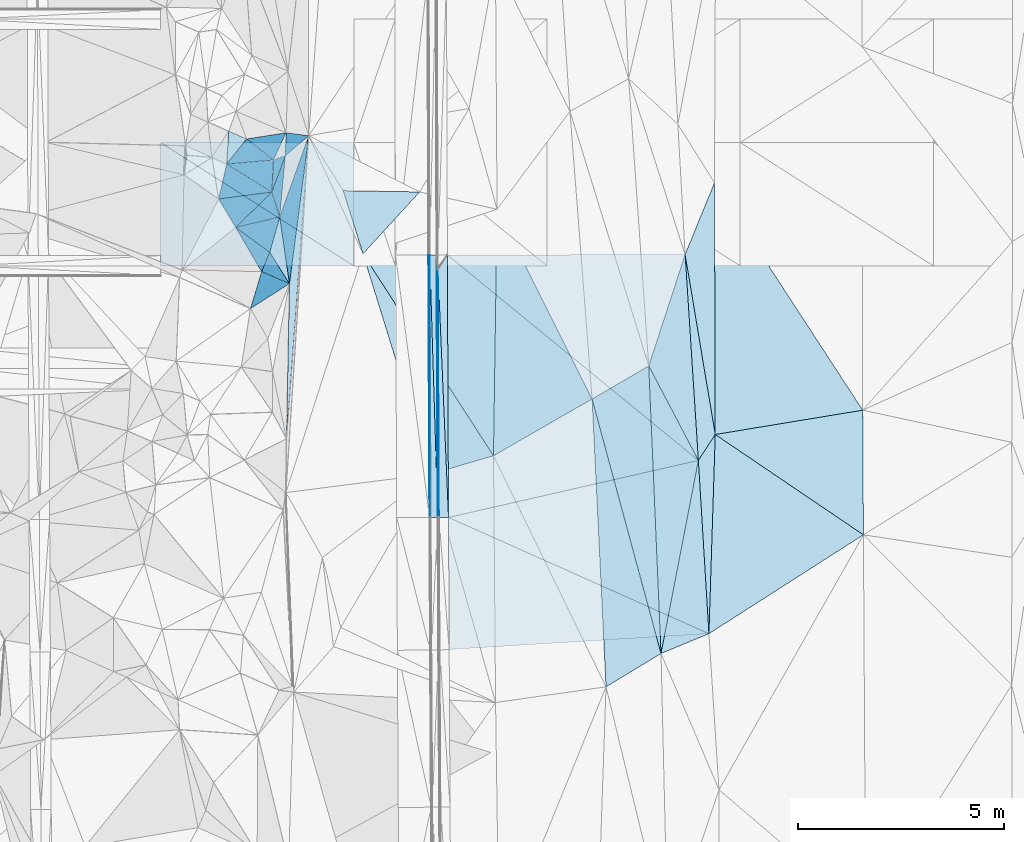
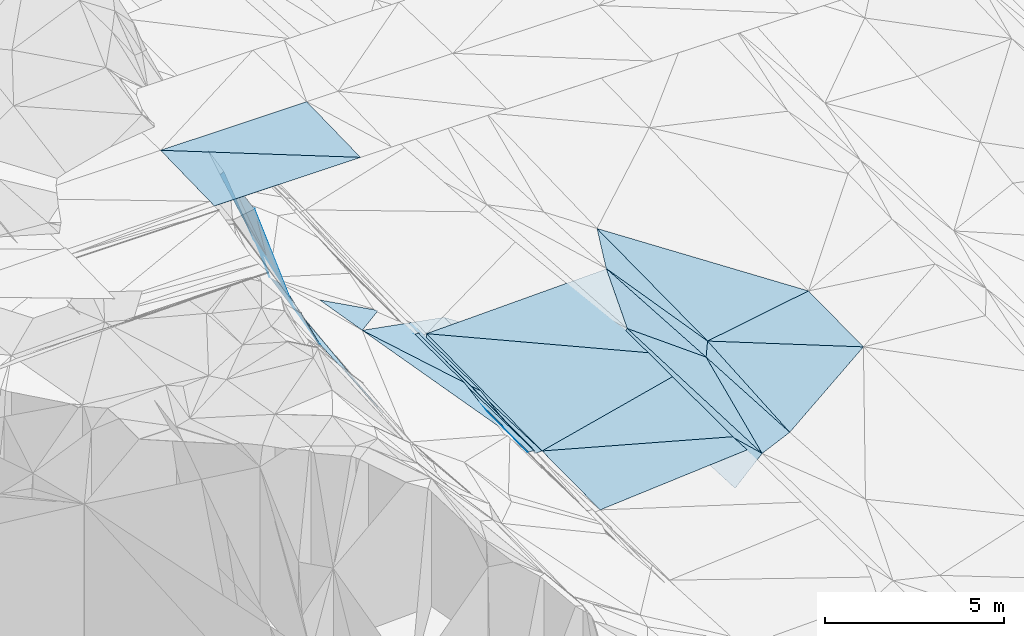
# One storey, part 64 of 275: 45 plates.
"""IFC2X3 building model written with IfcOpenShell, lengths in millimetres."""

from ifc_helpers import new_model, si_unit, frame, origin_with_axes, place, context, subcontext, project, spatial, polyline, outline, extrude, material, type_object, element, save


model = new_model("IFC2X3")

# Units and contexts
model_context = context("Model", 3, precision=1e-05, world=origin_with_axes())
body_context = subcontext(model_context, "Body", "Model", "MODEL_VIEW")
ifc_project = project(units=[si_unit("LENGTHUNIT", "METRE", prefix="MILLI"), si_unit("AREAUNIT", "SQUARE_METRE"), si_unit("VOLUMEUNIT", "CUBIC_METRE"), si_unit("MASSUNIT", "GRAM", prefix="KILO"), si_unit("TIMEUNIT", "SECOND"), si_unit("PLANEANGLEUNIT", "RADIAN"), si_unit("SOLIDANGLEUNIT", "STERADIAN"), si_unit("THERMODYNAMICTEMPERATUREUNIT", "DEGREE_CELSIUS"), si_unit("LUMINOUSINTENSITYUNIT", "LUMEN")], contexts=[model_context])

# Site, building, storey
site_placement = place(None, origin_with_axes())
site = spatial("IfcSite", under=ifc_project, at=site_placement, CompositionType="ELEMENT")
building_placement = place(site_placement, origin_with_axes())
building = spatial("IfcBuilding", under=site, at=building_placement, Name="Undefined", CompositionType="ELEMENT")
storey_placement = place(building_placement, origin_with_axes())
storey = spatial("IfcBuildingStorey", under=building, at=storey_placement, Name="Undefined", CompositionType="ELEMENT", Elevation=0.0)

# Plates
ifc_material = material()
plate_type_1 = type_object("IfcPlateType", PredefinedType="NOTDEFINED")
plate_1_placement = place(storey_placement, frame((-94083.1872128523, 60194.4197135059, 42150.4907383487), z_axis=(-0.970145132362982, 0.000666427097480044, -0.242524180294124), x_axis=(0.00428883012039787, -0.999792707106307, -0.0199034859569888)))
element("IfcPlate", 1, at=plate_1_placement, inside=storey, type_object=plate_type_1, material=ifc_material, Name="00_PR", context=body_context, shape_type="SweptSolid", body=[
    extrude(outline(polyline([(0.0, 0.0), (6024.77392578125, 2.10566213354468e-08), (6022.52880859375, 123.672775268555), (0.0, 0.0)])), frame((-8.85201319254618e-08, 2.18876761149539e-07, -0.5000001331573), z_axis=(0.0, 0.0, 1.0), x_axis=(1.0, 0.0, 0.0)), (0.0, 0.0, 1.0), 1.0),
])
plate_type_2 = type_object("IfcPlateType", PredefinedType="NOTDEFINED")
plate_2_placement = place(storey_placement, frame((-94314.0681795812, 60554.8896262147, 42276.9291978691), z_axis=(-0.020065563650007, 0.019660330856377, -0.99960534439649), x_axis=(0.999793129428669, 0.00372195810997011, -0.0199961340027595)))
element("IfcPlate", 2, at=plate_2_placement, inside=storey, type_object=plate_type_2, material=ifc_material, Name="00_PR", context=body_context, shape_type="SweptSolid", body=[
    extrude(outline(polyline([(0.0, 0.0), (30.0058002471924, -5.0931703299284e-11), (5.94980525970459, 6386.51708984375), (0.0, 0.0)])), frame((-8.85201319254618e-08, 2.18876761149539e-07, -0.5000001331573), z_axis=(0.0, 0.0, 1.0), x_axis=(1.0, 0.0, 0.0)), (0.0, 0.0, 1.0), 1.0),
])
plate_type_3 = type_object("IfcPlateType", PredefinedType="NOTDEFINED")
plate_3_placement = place(storey_placement, frame((-98123.6469206623, 62086.288405166, 45359.8035972877), z_axis=(-0.913769211210557, 0.103627770818292, -0.392793983862876), x_axis=(-0.363049939290338, 0.225508712957819, 0.904068892265069)))
element("IfcPlate", 3, at=plate_3_placement, inside=storey, type_object=plate_type_3, material=ifc_material, Name="00", context=body_context, shape_type="SweptSolid", body=[
    extrude(outline(polyline([(0.0, 0.0), (3030.74243164063, -3.17959347739816e-09), (271.319641113281, 743.831726074219), (0.0, 0.0)])), frame((-8.85201319254618e-08, 2.18876761149539e-07, -0.5000001331573), z_axis=(0.0, 0.0, 1.0), x_axis=(1.0, 0.0, 0.0)), (0.0, 0.0, 1.0), 1.0),
])
plate_type_4 = type_object("IfcPlateType", PredefinedType="NOTDEFINED")
plate_4_placement = place(storey_placement, frame((-94087.3466214836, 54170.622732035, 42150.5765485048), z_axis=(-0.970049928135875, 0.000666355314829428, -0.242904699201516), x_axis=(-0.00425875311728179, 0.999795874984663, 0.0197502249490374)))
element("IfcPlate", 4, at=plate_4_placement, inside=storey, type_object=plate_type_4, material=ifc_material, Name="00_PR", context=body_context, shape_type="SweptSolid", body=[
    extrude(outline(polyline([(0.0, 0.0), (6386.30712890625, -1.24055077321827e-08), (6022.5478515625, 122.733200073242), (0.0, 0.0)])), frame((-8.85201319254618e-08, 2.18876761149539e-07, -0.5000001331573), z_axis=(0.0, 0.0, 1.0), x_axis=(1.0, 0.0, 0.0)), (0.0, 0.0, 1.0), 1.0),
])
plate_type_5 = type_object("IfcPlateType", PredefinedType="NOTDEFINED")
plate_5_placement = place(storey_placement, frame((-94082.6878946464, 60194.429312966, 42150.1123022078), z_axis=(0.0284912506383078, 0.0198645565682699, -0.999396641994264), x_axis=(0.533549753588131, 0.84516273356922, 0.0320095959338333)))
element("IfcPlate", 5, at=plate_5_placement, inside=storey, type_object=plate_type_5, material=ifc_material, Name="00_PR", context=body_context, shape_type="SweptSolid", body=[
    extrude(outline(polyline([(0.0, 0.0), (428.527740478516, -2.09547579288483e-09), (-4957.13232421875, 3431.6259765625), (0.0, 0.0)])), frame((-8.85201319254618e-08, 2.18876761149539e-07, -0.5000001331573), z_axis=(0.0, 0.0, 1.0), x_axis=(1.0, 0.0, 0.0)), (0.0, 0.0, 1.0), 1.0),
])
plate_6_placement = place(storey_placement, frame((-93826.8480910763, 54171.8780020945, 42037.6983648628), z_axis=(0.0325003277744635, 0.0200325159705052, -0.999270947740624), x_axis=(-0.999459808725108, -0.00423071512812767, -0.0325912839985746)))
element("IfcPlate", 6, at=plate_6_placement, inside=storey, type_object=plate_type_5, material=ifc_material, Name="00_PR", context=body_context, shape_type="SweptSolid", body=[
    extrude(outline(polyline([(0.0, 0.0), (230.12287902832, -1.17870513349772e-09), (226.556182861328, 6024.77294921875), (0.0, 0.0)])), frame((-8.85201319254618e-08, 2.18876761149539e-07, -0.5000001331573), z_axis=(0.0, 0.0, 1.0), x_axis=(1.0, 0.0, 0.0)), (0.0, 0.0, 1.0), 1.0),
])
plate_type_6 = type_object("IfcPlateType", PredefinedType="NOTDEFINED")
plate_7_placement = place(storey_placement, frame((-97777.6343398403, 63529.4901623154, 45289.8521627805), z_axis=(-0.930604738653732, 0.215773372980905, -0.295663105421799), x_axis=(0.294531549131912, -0.0381436978772453, -0.954880214937039)))
element("IfcPlate", 7, at=plate_7_placement, inside=storey, type_object=plate_type_6, material=ifc_material, Name="00", context=body_context, shape_type="SweptSolid", body=[
    extrude(outline(polyline([(0.0, 0.0), (1870.39172363281, -4.16184775531292e-09), (350.247497558594, 554.460693359375), (0.0, 0.0)])), frame((-8.85201319254618e-08, 2.18876761149539e-07, -0.5000001331573), z_axis=(0.0, 0.0, 1.0), x_axis=(1.0, 0.0, 0.0)), (0.0, 0.0, 1.0), 1.0),
])
plate_type_7 = type_object("IfcPlateType", PredefinedType="NOTDEFINED")
plate_8_placement = place(storey_placement, frame((-94086.8616436394, 54170.6322714829, 42150.1980982613), z_axis=(-9.4600295512822e-05, 0.0197494443997183, -0.999804956227307), x_axis=(-0.999988528032138, -0.00478996911455793, -1.84466555989059e-11)))
element("IfcPlate", 8, at=plate_8_placement, inside=storey, type_object=plate_type_7, material=ifc_material, Name="00_PR", context=body_context, shape_type="SweptSolid", body=[
    extrude(outline(polyline([(0.0, 0.0), (170.000335693359, -2.03726813197136e-10), (166.61376953125, 6386.48583984375), (0.0, 0.0)])), frame((-8.85201319254618e-08, 2.18876761149539e-07, -0.5000001331573), z_axis=(0.0, 0.0, 1.0), x_axis=(1.0, 0.0, 0.0)), (0.0, 0.0, 1.0), 1.0),
])
plate_9_placement = place(storey_placement, frame((-94086.8616436394, 54170.6322714829, 42150.1980982613), z_axis=(-7.36880057852465e-05, 0.0197500905871008, -0.999804945222757), x_axis=(-0.0308667211149853, 0.999328505195468, 0.019742953968495)))
element("IfcPlate", 9, at=plate_9_placement, inside=storey, type_object=plate_type_7, material=ifc_material, Name="00_PR", context=body_context, shape_type="SweptSolid", body=[
    extrude(outline(polyline([(0.0, 0.0), (6388.6591796875, -2.11002770811319e-08), (6384.04541015625, 169.93782043457), (0.0, 0.0)])), frame((-8.85201319254618e-08, 2.18876761149539e-07, -0.5000001331573), z_axis=(0.0, 0.0, 1.0), x_axis=(1.0, 0.0, 0.0)), (0.0, 0.0, 1.0), 1.0),
])
plate_type_8 = type_object("IfcPlateType", PredefinedType="NOTDEFINED")
plate_10_placement = place(storey_placement, frame((-88070.556139504, 60567.2472432534, 42332.1123125707), z_axis=(0.0290420819930306, 0.0200636895037129, -0.999376808734828), x_axis=(0.0642000891350133, -0.997771693494683, -0.0181657979678707)))
element("IfcPlate", 10, at=plate_10_placement, inside=storey, type_object=plate_type_8, material=ifc_material, Name="00_PR", context=body_context, shape_type="SweptSolid", body=[
    extrude(outline(polyline([(0.0, 0.0), (5018.4970703125, -2.5029294192791e-09), (-357.625183105469, 5774.88525390625), (0.0, 0.0)])), frame((-8.85201319254618e-08, 2.18876761149539e-07, -0.5000001331573), z_axis=(0.0, 0.0, 1.0), x_axis=(1.0, 0.0, 0.0)), (0.0, 0.0, 1.0), 1.0),
])
plate_type_9 = type_object("IfcPlateType", PredefinedType="NOTDEFINED")
plate_11_placement = place(storey_placement, frame((-87748.3683080313, 55559.9331595305, 42240.9473106879), z_axis=(0.0288081636947185, 0.0201817193886424, -0.999381202498354), x_axis=(0.0607675931301409, -0.997982301450633, -0.0184017829698086)))
element("IfcPlate", 11, at=plate_11_placement, inside=storey, type_object=plate_type_9, material=ifc_material, Name="00_PR", context=body_context, shape_type="SweptSolid", body=[
    extrude(outline(polyline([(0.0, 0.0), (4224.75390625, 9.69157554209232e-09), (1019.61987304688, 6154.3740234375), (0.0, 0.0)])), frame((-8.85201319254618e-08, 2.18876761149539e-07, -0.5000001331573), z_axis=(0.0, 0.0, 1.0), x_axis=(1.0, 0.0, 0.0)), (0.0, 0.0, 1.0), 1.0),
])
plate_type_10 = type_object("IfcPlateType", PredefinedType="NOTDEFINED")
plate_12_placement = place(storey_placement, frame((-93826.8498970486, 54171.8779179057, 42037.6983083338), z_axis=(0.0288804031159279, 0.0198659925913837, -0.999385443487257), x_axis=(-0.00425875311728179, 0.999795874984663, 0.0197502249490374)))
element("IfcPlate", 12, at=plate_12_placement, inside=storey, type_object=plate_type_10, material=ifc_material, Name="00_PR", context=body_context, shape_type="SweptSolid", body=[
    extrude(outline(polyline([(0.0, 0.0), (6386.03076171875, 1.29366526380181e-08), (1365.89892578125, 6086.89306640625), (0.0, 0.0)])), frame((-8.85201319254618e-08, 2.18876761149539e-07, -0.5000001331573), z_axis=(0.0, 0.0, 1.0), x_axis=(1.0, 0.0, 0.0)), (0.0, 0.0, 1.0), 1.0),
])
plate_type_11 = type_object("IfcPlateType", PredefinedType="NOTDEFINED")
plate_13_placement = place(storey_placement, frame((-93810.6037731778, 50959.198992002, 41976.1182963154), z_axis=(0.0284151967306764, 0.0193001887801418, -0.999409865524554), x_axis=(-0.00505595711942665, 0.999803569123067, 0.019164040972191)))
element("IfcPlate", 13, at=plate_13_placement, inside=storey, type_object=plate_type_11, material=ifc_material, Name="00_PR", context=body_context, shape_type="SweptSolid", body=[
    extrude(outline(polyline([(0.0, 0.0), (3213.30981445313, -3.71073838323355e-09), (356.065673828125, 6323.39794921875), (0.0, 0.0)])), frame((-8.85201319254618e-08, 2.18876761149539e-07, -0.5000001331573), z_axis=(0.0, 0.0, 1.0), x_axis=(1.0, 0.0, 0.0)), (0.0, 0.0, 1.0), 1.0),
])
plate_type_12 = type_object("IfcPlateType", PredefinedType="NOTDEFINED")
plate_14_placement = place(storey_placement, frame((-87337.9509343593, 56189.6595155575, 42279.5002101555), z_axis=(0.0204693586901245, 0.0220398705482143, -0.99954752236251), x_axis=(0.828024545312724, -0.560673030448567, 0.00459404911576237)))
element("IfcPlate", 14, at=plate_14_placement, inside=storey, type_object=plate_type_12, material=ifc_material, Name="00", context=body_context, shape_type="SweptSolid", body=[
    extrude(outline(polyline([(0.0, 0.0), (4353.45849609375, -1.00858414953109e-08), (2589.22875976563, 4100.5966796875), (0.0, 0.0)])), frame((-8.85201319254618e-08, 2.18876761149539e-07, -0.5000001331573), z_axis=(0.0, 0.0, 1.0), x_axis=(1.0, 0.0, 0.0)), (0.0, 0.0, 1.0), 1.0),
])
plate_type_13 = type_object("IfcPlateType", PredefinedType="NOTDEFINED")
for number, where, z_axis, x_axis, name in (
    (15, (-96130.6050987727, 60292.4118257655, 49116.774151513), (0.00186616395212177, 0.024992040727705, -0.999685908339399), (-0.999998258658335, 5.7237979883395e-05, -0.00186531608879618), "00_PR"),
    (16, (-100830.43335215, 63292.6808659831, 49183.0071510477), (0.00186616395212177, 0.024992040727705, -0.999685908339399), (0.999998258658335, -5.72379768289894e-05, 0.00186531608878231), "00_PR"),
):
    element("IfcPlate", number, at=place(storey_placement, frame(where, z_axis=z_axis, x_axis=x_axis)), inside=storey, type_object=plate_type_13, material=ifc_material, Name=name, context=body_context, shape_type="SweptSolid", body=[
        extrude(outline(polyline([(0.0, 0.0), (4700.00830078125, 9.19681042432785e-09), (4699.8681640625, 3000.93725585938), (0.0, 0.0)])), frame((-8.85201319254618e-08, 2.18876761149539e-07, -0.5000001331573), z_axis=(0.0, 0.0, 1.0), x_axis=(1.0, 0.0, 0.0)), (0.0, 0.0, 1.0), 1.0),
    ])
plate_type_14 = type_object("IfcPlateType", PredefinedType="NOTDEFINED")
plate_15_placement = place(storey_placement, frame((-99001.5813481174, 61227.9039828314, 47799.8143506814), z_axis=(-0.921641928173209, -0.112789698180397, -0.371287813182097), x_axis=(-0.360827201206409, 0.601110872841329, 0.713070437910229)))
element("IfcPlate", 17, at=plate_15_placement, inside=storey, type_object=plate_type_14, material=ifc_material, Name="00", context=body_context, shape_type="SweptSolid", body=[
    extrude(outline(polyline([(0.0, 0.0), (1149.95654296875, -8.65838956087828e-10), (-1540.75390625, 2255.455078125), (0.0, 0.0)])), frame((-8.85201319254618e-08, 2.18876761149539e-07, -0.5000001331573), z_axis=(0.0, 0.0, 1.0), x_axis=(1.0, 0.0, 0.0)), (0.0, 0.0, 1.0), 1.0),
])
plate_type_15 = type_object("IfcPlateType", PredefinedType="NOTDEFINED")
plate_16_placement = place(storey_placement, frame((-99172.5846568805, 63568.8206919854, 48479.7454293091), z_axis=(-0.808881868270968, 0.294102963442956, -0.509130209353697), x_axis=(0.46687585996136, -0.205078016765932, -0.860215053591073)))
element("IfcPlate", 18, at=plate_16_placement, inside=storey, type_object=plate_type_15, material=ifc_material, Name="00", context=body_context, shape_type="SweptSolid", body=[
    extrude(outline(polyline([(0.0, 0.0), (930.0, 3.17231751978397e-09), (466.774200439453, 753.340454101563), (0.0, 0.0)])), frame((-8.85201319254618e-08, 2.18876761149539e-07, -0.5000001331573), z_axis=(0.0, 0.0, 1.0), x_axis=(1.0, 0.0, 0.0)), (0.0, 0.0, 1.0), 1.0),
])
plate_type_16 = type_object("IfcPlateType", PredefinedType="NOTDEFINED")
plate_17_placement = place(storey_placement, frame((-98372.1320256533, 60150.4836785749, 44909.7690128733), z_axis=(-0.885120434130772, 0.0561475956507611, -0.461962406031911), x_axis=(0.444496381890832, -0.191914312744009, -0.874981064395084)))
element("IfcPlate", 19, at=plate_17_placement, inside=storey, type_object=plate_type_16, material=ifc_material, Name="00", context=body_context, shape_type="SweptSolid", body=[
    extrude(outline(polyline([(0.0, 0.0), (1520.03283691406, 1.04046193882823e-09), (-307.164398193359, 974.65380859375), (0.0, 0.0)])), frame((-8.85201319254618e-08, 2.18876761149539e-07, -0.5000001331573), z_axis=(0.0, 0.0, 1.0), x_axis=(1.0, 0.0, 0.0)), (0.0, 0.0, 1.0), 1.0),
])
plate_type_17 = type_object("IfcPlateType", PredefinedType="NOTDEFINED")
plate_18_placement = place(storey_placement, frame((-98123.6627399396, 62086.2630098731, 45359.8392046935), z_axis=(-0.945407332295884, 0.052836474411999, -0.321579357255545), x_axis=(0.208408782211849, -0.660593872831116, -0.721236101893799)))
element("IfcPlate", 20, at=plate_18_placement, inside=storey, type_object=plate_type_17, material=ifc_material, Name="00", context=body_context, shape_type="SweptSolid", body=[
    extrude(outline(polyline([(0.0, 0.0), (915.095642089844, 4.69299266114831e-10), (-1375.8125, 2359.69067382813), (0.0, 0.0)])), frame((-8.85201319254618e-08, 2.18876761149539e-07, -0.5000001331573), z_axis=(0.0, 0.0, 1.0), x_axis=(1.0, 0.0, 0.0)), (0.0, 0.0, 1.0), 1.0),
])
plate_type_18 = type_object("IfcPlateType", PredefinedType="NOTDEFINED")
plate_19_placement = place(storey_placement, frame((-97932.9290452422, 61481.8037736526, 44699.8015590898), z_axis=(-0.905947545950411, 0.14748839385182, -0.396870530104514), x_axis=(-0.208408782207984, 0.660593872834045, 0.721236101892232)))
element("IfcPlate", 21, at=plate_19_placement, inside=storey, type_object=plate_type_18, material=ifc_material, Name="00", context=body_context, shape_type="SweptSolid", body=[
    extrude(outline(polyline([(0.0, 0.0), (915.095642089844, 4.69299266114831e-10), (1130.81079101563, 1013.83776855469), (0.0, 0.0)])), frame((-8.85201319254618e-08, 2.18876761149539e-07, -0.5000001331573), z_axis=(0.0, 0.0, 1.0), x_axis=(1.0, 0.0, 0.0)), (0.0, 0.0, 1.0), 1.0),
])
plate_type_19 = type_object("IfcPlateType", PredefinedType="NOTDEFINED")
plate_20_placement = place(storey_placement, frame((-87748.3755034507, 55559.9342042616, 42259.5001622033), z_axis=(0.0146078542017197, 0.0222280140055859, -0.999646200407419), x_axis=(0.545823644667066, 0.837477811734955, 0.0265981911789623)))
element("IfcPlate", 22, at=plate_20_placement, inside=storey, type_object=plate_type_19, material=ifc_material, Name="00", context=body_context, shape_type="SweptSolid", body=[
    extrude(outline(polyline([(0.0, 0.0), (751.930847167969, -1.01863406598568e-10), (-3393.26416015625, 2517.21240234375), (0.0, 0.0)])), frame((-8.85201319254618e-08, 2.18876761149539e-07, -0.5000001331573), z_axis=(0.0, 0.0, 1.0), x_axis=(1.0, 0.0, 0.0)), (0.0, 0.0, 1.0), 1.0),
])
plate_type_20 = type_object("IfcPlateType", PredefinedType="NOTDEFINED")
plate_21_placement = place(storey_placement, frame((-88657.0888002002, 50861.2631277043, 42150.5003070337), z_axis=(0.0316494046003667, 0.0170620709412023, -0.999353391410486), x_axis=(-0.0426307116336391, 0.998967448775915, 0.0157053720665517)))
element("IfcPlate", 23, at=plate_21_placement, inside=storey, type_object=plate_type_20, material=ifc_material, Name="00", context=body_context, shape_type="SweptSolid", body=[
    extrude(outline(polyline([(0.0, 0.0), (7003.97265625, 2.41270754486322e-08), (4656.78955078125, 1108.80810546875), (0.0, 0.0)])), frame((-8.85201319254618e-08, 2.18876761149539e-07, -0.5000001331573), z_axis=(0.0, 0.0, 1.0), x_axis=(1.0, 0.0, 0.0)), (0.0, 0.0, 1.0), 1.0),
])
plate_type_21 = type_object("IfcPlateType", PredefinedType="NOTDEFINED")
plate_22_placement = place(storey_placement, frame((-98086.5613482172, 62868.1406280817, 45479.8318394044), z_axis=(-0.88660486839337, 0.317533597433784, -0.336309711191834), x_axis=(-0.277327710086692, 0.216959077830942, 0.935958385701426)))
element("IfcPlate", 24, at=plate_22_placement, inside=storey, type_object=plate_type_21, material=ifc_material, Name="00", context=body_context, shape_type="SweptSolid", body=[
    extrude(outline(polyline([(0.0, 0.0), (2350.53173828125, -2.62298271991313e-09), (-120.01538848877, 744.712219238281), (0.0, 0.0)])), frame((-8.85201319254618e-08, 2.18876761149539e-07, -0.5000001331573), z_axis=(0.0, 0.0, 1.0), x_axis=(1.0, 0.0, 0.0)), (0.0, 0.0, 1.0), 1.0),
])
plate_type_22 = type_object("IfcPlateType", PredefinedType="NOTDEFINED")
plate_23_placement = place(storey_placement, frame((-98123.6317739079, 62086.2924575783, 45359.7725182396), z_axis=(-0.883478514575878, 0.11173277606206, -0.454952196429764), x_axis=(0.0468216537605174, 0.987338625770043, 0.151559133019601)))
element("IfcPlate", 25, at=plate_23_placement, inside=storey, type_object=plate_type_22, material=ifc_material, Name="00", context=body_context, shape_type="SweptSolid", body=[
    extrude(outline(polyline([(0.0, 0.0), (791.770141601563, 1.86264514923096e-09), (829.281066894531, 621.846374511719), (0.0, 0.0)])), frame((-8.85201319254618e-08, 2.18876761149539e-07, -0.5000001331573), z_axis=(0.0, 0.0, 1.0), x_axis=(1.0, 0.0, 0.0)), (0.0, 0.0, 1.0), 1.0),
])
plate_type_23 = type_object("IfcPlateType", PredefinedType="NOTDEFINED")
plate_24_placement = place(storey_placement, frame((-98738.4032029215, 63378.1647427532, 47679.826749884), z_axis=(-0.835074052187775, 0.427313788758456, -0.346488460557611), x_axis=(0.277327710092976, -0.216959077835374, -0.935958385698537)))
element("IfcPlate", 26, at=plate_24_placement, inside=storey, type_object=plate_type_23, material=ifc_material, Name="00", context=body_context, shape_type="SweptSolid", body=[
    extrude(outline(polyline([(0.0, 0.0), (2350.53173828125, -2.62298271991313e-09), (-395.782775878906, 790.857788085938), (0.0, 0.0)])), frame((-8.85201319254618e-08, 2.18876761149539e-07, -0.5000001331573), z_axis=(0.0, 0.0, 1.0), x_axis=(1.0, 0.0, 0.0)), (0.0, 0.0, 1.0), 1.0),
])
plate_type_24 = type_object("IfcPlateType", PredefinedType="NOTDEFINED")
plate_25_placement = place(storey_placement, frame((-99223.9655043188, 62769.6877191289, 48099.8153487308), z_axis=(-0.929186002196396, -0.0154166599747725, -0.369290806705908), x_axis=(0.363049939294403, -0.225508712958993, -0.904068892263144)))
element("IfcPlate", 27, at=plate_25_placement, inside=storey, type_object=plate_type_24, material=ifc_material, Name="00", context=body_context, shape_type="SweptSolid", body=[
    extrude(outline(polyline([(0.0, 0.0), (3030.74243164063, -3.17959347739816e-09), (-348.231506347656, 953.695373535156), (0.0, 0.0)])), frame((-8.85201319254618e-08, 2.18876761149539e-07, -0.5000001331573), z_axis=(0.0, 0.0, 1.0), x_axis=(1.0, 0.0, 0.0)), (0.0, 0.0, 1.0), 1.0),
])
plate_type_25 = type_object("IfcPlateType", PredefinedType="NOTDEFINED")
plate_26_placement = place(storey_placement, frame((-98175.2644844517, 60620.3061709079, 44689.8523435833), z_axis=(-0.918817026594382, 0.261862661053092, -0.29530191057027), x_axis=(-0.252325648153315, 0.185594712879437, 0.949676981839198)))
element("IfcPlate", 28, at=plate_26_placement, inside=storey, type_object=plate_type_25, material=ifc_material, Name="00", context=body_context, shape_type="SweptSolid", body=[
    extrude(outline(polyline([(0.0, 0.0), (3274.79760742188, -6.87577994540334e-10), (108.250961303711, 888.471557617188), (0.0, 0.0)])), frame((-8.85201319254618e-08, 2.18876761149539e-07, -0.5000001331573), z_axis=(0.0, 0.0, 1.0), x_axis=(1.0, 0.0, 0.0)), (0.0, 0.0, 1.0), 1.0),
])
plate_type_26 = type_object("IfcPlateType", PredefinedType="NOTDEFINED")
plate_27_placement = place(storey_placement, frame((-99001.5819286564, 61228.0849542956, 47799.8530560247), z_axis=(-0.922799799171805, 0.249153075573005, -0.293876292989055), x_axis=(0.252325648149838, -0.185594712871748, -0.949676981841625)))
element("IfcPlate", 29, at=plate_27_placement, inside=storey, type_object=plate_type_26, material=ifc_material, Name="00", context=body_context, shape_type="SweptSolid", body=[
    extrude(outline(polyline([(0.0, 0.0), (3274.79760742188, -6.87577994540334e-10), (3103.3671875, 527.647216796875), (0.0, 0.0)])), frame((-8.85201319254618e-08, 2.18876761149539e-07, -0.5000001331573), z_axis=(0.0, 0.0, 1.0), x_axis=(1.0, 0.0, 0.0)), (0.0, 0.0, 1.0), 1.0),
])
plate_type_27 = type_object("IfcPlateType", PredefinedType="NOTDEFINED")
plate_28_placement = place(storey_placement, frame((-97932.9391639327, 61481.7866714505, 44699.8201551268), z_axis=(-0.926173803295044, 0.113284401146821, -0.359678649000466), x_axis=(0.292353202947195, 0.818157884212633, -0.495123500984577)))
element("IfcPlate", 30, at=plate_28_placement, inside=storey, type_object=plate_type_27, material=ifc_material, Name="00", context=body_context, shape_type="SweptSolid", body=[
    extrude(outline(polyline([(0.0, 0.0), (2415.55883789063, -2.73576006293297e-09), (-704.201416015625, 1857.01379394531), (0.0, 0.0)])), frame((-8.85201319254618e-08, 2.18876761149539e-07, -0.5000001331573), z_axis=(0.0, 0.0, 1.0), x_axis=(1.0, 0.0, 0.0)), (0.0, 0.0, 1.0), 1.0),
])
plate_type_28 = type_object("IfcPlateType", PredefinedType="NOTDEFINED")
plate_29_placement = place(storey_placement, frame((-97696.4750454344, 59858.810972784, 43579.7634947977), z_axis=(-0.869400971440667, 0.142875894740148, -0.472999396997742), x_axis=(-0.444496382287005, 0.191914312902946, 0.874981064158965)))
element("IfcPlate", 31, at=plate_29_placement, inside=storey, type_object=plate_type_28, material=ifc_material, Name="00", context=body_context, shape_type="SweptSolid", body=[
    extrude(outline(polyline([(0.0, 0.0), (1520.03283691406, 1.04046193882823e-09), (1330.16857910156, 521.297912597656), (0.0, 0.0)])), frame((-8.85201319254618e-08, 2.18876761149539e-07, -0.5000001331573), z_axis=(0.0, 0.0, 1.0), x_axis=(1.0, 0.0, 0.0)), (0.0, 0.0, 1.0), 1.0),
])
plate_type_29 = type_object("IfcPlateType", PredefinedType="NOTDEFINED")
plate_30_placement = place(storey_placement, frame((-97696.4514440355, 59858.8581689836, 43579.7412993438), z_axis=(-0.822200216701441, 0.237265064797872, -0.517389691318415), x_axis=(-0.335112022332216, 0.532967953067346, 0.776946004231707)))
element("IfcPlate", 32, at=plate_30_placement, inside=storey, type_object=plate_type_29, material=ifc_material, Name="00", context=body_context, shape_type="SweptSolid", body=[
    extrude(outline(polyline([(0.0, 0.0), (1428.67065429688, 1.70985003933311e-09), (1814.41394042969, 807.652282714844), (0.0, 0.0)])), frame((-8.85201319254618e-08, 2.18876761149539e-07, -0.5000001331573), z_axis=(0.0, 0.0, 1.0), x_axis=(1.0, 0.0, 0.0)), (0.0, 0.0, 1.0), 1.0),
])
plate_type_30 = type_object("IfcPlateType", PredefinedType="NOTDEFINED")
plate_31_placement = place(storey_placement, frame((-97226.4938464735, 63458.0570432922, 43503.5485588317), z_axis=(-0.428329939108985, 0.0368389357856878, -0.902871173575207), x_axis=(-0.0732234527666134, -0.997297787627016, -0.00595388605822988)))
element("IfcPlate", 33, at=plate_31_placement, inside=storey, type_object=plate_type_30, material=ifc_material, Name="00", context=body_context, shape_type="SweptSolid", body=[
    extrude(outline(polyline([(0.0, 0.0), (7390.1318359375, 1.17142917588353e-08), (3623.51806640625, 226.984939575195), (0.0, 0.0)])), frame((-8.85201319254618e-08, 2.18876761149539e-07, -0.5000001331573), z_axis=(0.0, 0.0, 1.0), x_axis=(1.0, 0.0, 0.0)), (0.0, 0.0, 1.0), 1.0),
])
plate_type_31 = type_object("IfcPlateType", PredefinedType="NOTDEFINED")
plate_32_placement = place(storey_placement, frame((-88955.6187566922, 57858.006279279, 42260.5050596107), z_axis=(0.14041988972749, 0.021554534558394, -0.989857392056498), x_axis=(0.0426307115274827, -0.998967448781228, -0.0157053720167448)))
element("IfcPlate", 34, at=plate_32_placement, inside=storey, type_object=plate_type_31, material=ifc_material, Name="00", context=body_context, shape_type="SweptSolid", body=[
    extrude(outline(polyline([(0.0, 0.0), (7003.97265625, 2.41270754486322e-08), (749.695373535156, 1425.17431640625), (0.0, 0.0)])), frame((-8.85201319254618e-08, 2.18876761149539e-07, -0.5000001331573), z_axis=(0.0, 0.0, 1.0), x_axis=(1.0, 0.0, 0.0)), (0.0, 0.0, 1.0), 1.0),
])
plate_type_32 = type_object("IfcPlateType", PredefinedType="NOTDEFINED")
plate_33_placement = place(storey_placement, frame((-87491.6510486756, 51343.7045489788, 42169.500115993), z_axis=(0.00728099282564977, 0.0217837985726358, -0.999736191834236), x_axis=(-0.923860505484686, -0.382432895479751, -0.0150614362048749)))
element("IfcPlate", 35, at=plate_33_placement, inside=storey, type_object=plate_type_32, material=ifc_material, Name="00", context=body_context, shape_type="SweptSolid", body=[
    extrude(outline(polyline([(0.0, 0.0), (1261.49987792969, 5.29689714312553e-09), (-1376.59936523438, 3994.44287109375), (0.0, 0.0)])), frame((-8.85201319254618e-08, 2.18876761149539e-07, -0.5000001331573), z_axis=(0.0, 0.0, 1.0), x_axis=(1.0, 0.0, 0.0)), (0.0, 0.0, 1.0), 1.0),
])
plate_type_33 = type_object("IfcPlateType", PredefinedType="NOTDEFINED")
plate_34_placement = place(storey_placement, frame((-88070.5611371834, 60567.2468353679, 42349.5001704255), z_axis=(0.0192448743108992, 0.0192053452830933, -0.999630326433385), x_axis=(0.165038580604643, -0.986161040495894, -0.015769246020692)))
element("IfcPlate", 36, at=plate_34_placement, inside=storey, type_object=plate_type_33, material=ifc_material, Name="00", context=body_context, shape_type="SweptSolid", body=[
    extrude(outline(polyline([(0.0, 0.0), (4439.02001953125, 1.01717887446284e-08), (4992.61083984375, 508.858917236328), (0.0, 0.0)])), frame((-8.85201319254618e-08, 2.18876761149539e-07, -0.5000001331573), z_axis=(0.0, 0.0, 1.0), x_axis=(1.0, 0.0, 0.0)), (0.0, 0.0, 1.0), 1.0),
])
plate_type_34 = type_object("IfcPlateType", PredefinedType="NOTDEFINED")
plate_35_placement = place(storey_placement, frame((-88657.0283303571, 50861.2670379324, 42150.5059958844), z_axis=(0.152588540382769, 0.0248808910038708, -0.987976557721239), x_axis=(-0.846513572608305, -0.512620212403738, -0.143649884180498)))
element("IfcPlate", 37, at=plate_35_placement, inside=storey, type_object=plate_type_34, material=ifc_material, Name="00", context=body_context, shape_type="SweptSolid", body=[
    extrude(outline(polyline([(0.0, 0.0), (1580.23095703125, 3.62342689186335e-09), (-1739.67541503906, 6174.19140625), (0.0, 0.0)])), frame((-8.85201319254618e-08, 2.18876761149539e-07, -0.5000001331573), z_axis=(0.0, 0.0, 1.0), x_axis=(1.0, 0.0, 0.0)), (0.0, 0.0, 1.0), 1.0),
])
plate_type_35 = type_object("IfcPlateType", PredefinedType="NOTDEFINED")
plate_36_placement = place(storey_placement, frame((-88955.6699663738, 57858.0057100336, 42260.500449052), z_axis=(0.0380081503106535, 0.0204025521655484, -0.999069124923343), x_axis=(0.31039881750291, 0.950093912532703, 0.0312110791402053)))
element("IfcPlate", 38, at=plate_36_placement, inside=storey, type_object=plate_type_35, material=ifc_material, Name="00", context=body_context, shape_type="SweptSolid", body=[
    extrude(outline(polyline([(0.0, 0.0), (2851.55151367188, 8.81846062839031e-09), (-1808.66943359375, 1862.10656738281), (0.0, 0.0)])), frame((-8.85201319254618e-08, 2.18876761149539e-07, -0.5000001331573), z_axis=(0.0, 0.0, 1.0), x_axis=(1.0, 0.0, 0.0)), (0.0, 0.0, 1.0), 1.0),
])
plate_type_36 = type_object("IfcPlateType", PredefinedType="NOTDEFINED")
plate_37_placement = place(storey_placement, frame((-92732.5714744899, 55672.2832263836, 41595.5292888989), z_axis=(-0.333648719874442, 0.0496379789789869, -0.941389718856664), x_axis=(-0.912465682787658, -0.267874399487293, 0.309272830740391)))
element("IfcPlate", 39, at=plate_37_placement, inside=storey, type_object=plate_type_36, material=ifc_material, Name="00", context=body_context, shape_type="SweptSolid", body=[
    extrude(outline(polyline([(0.0, 0.0), (1661.96301269531, 5.54427970200777e-09), (2008.57116699219, 5664.28857421875), (0.0, 0.0)])), frame((-8.85201319254618e-08, 2.18876761149539e-07, -0.5000001331573), z_axis=(0.0, 0.0, 1.0), x_axis=(1.0, 0.0, 0.0)), (0.0, 0.0, 1.0), 1.0),
])
plate_type_37 = type_object("IfcPlateType", PredefinedType="NOTDEFINED")
plate_38_placement = place(storey_placement, frame((-95906.8227627659, 60584.250163354, 42979.5585431054), z_axis=(-0.469525958597481, 0.0077575977503597, -0.882884586953618), x_axis=(-0.295435472768462, 0.940939086181605, 0.165382942064171)))
element("IfcPlate", 40, at=plate_38_placement, inside=storey, type_object=plate_type_37, material=ifc_material, Name="00", context=body_context, shape_type="SweptSolid", body=[
    extrude(outline(polyline([(0.0, 0.0), (1632.57470703125, 2.4156179279089e-09), (890.740295410156, 1973.39343261719), (0.0, 0.0)])), frame((-8.85201319254618e-08, 2.18876761149539e-07, -0.5000001331573), z_axis=(0.0, 0.0, 1.0), x_axis=(1.0, 0.0, 0.0)), (0.0, 0.0, 1.0), 1.0),
])
plate_type_38 = type_object("IfcPlateType", PredefinedType="NOTDEFINED")
plate_39_placement = place(storey_placement, frame((-90333.3820327329, 57052.078236256, 42047.5085315531), z_axis=(0.184091440821145, 0.00192162151895979, -0.982907243226508), x_axis=(-0.855503031782539, -0.49206894053296, -0.161191564213688)))
element("IfcPlate", 41, at=plate_39_placement, inside=storey, type_object=plate_type_38, material=ifc_material, Name="00", context=body_context, shape_type="SweptSolid", body=[
    extrude(outline(polyline([(0.0, 0.0), (2804.11694335938, 9.00763552635908e-09), (-225.275909423828, 5175.43994140625), (0.0, 0.0)])), frame((-8.85201319254618e-08, 2.18876761149539e-07, -0.5000001331573), z_axis=(0.0, 0.0, 1.0), x_axis=(1.0, 0.0, 0.0)), (0.0, 0.0, 1.0), 1.0),
])
plate_type_39 = type_object("IfcPlateType", PredefinedType="NOTDEFINED")
plate_40_placement = place(storey_placement, frame((-95906.7813662481, 60584.2512404293, 42979.5389157588), z_axis=(-0.386731372457766, 0.00991132162467316, -0.922139149619289), x_axis=(0.882701889616159, 0.293463188528826, -0.367037778772916)))
element("IfcPlate", 42, at=plate_40_placement, inside=storey, type_object=plate_type_39, material=ifc_material, Name="00", context=body_context, shape_type="SweptSolid", body=[
    extrude(outline(polyline([(0.0, 0.0), (3694.44262695313, 2.16823536902666e-09), (1868.35034179688, 5712.07373046875), (0.0, 0.0)])), frame((-8.85201319254618e-08, 2.18876761149539e-07, -0.5000001331573), z_axis=(0.0, 0.0, 1.0), x_axis=(1.0, 0.0, 0.0)), (0.0, 0.0, 1.0), 1.0),
])
plate_type_40 = type_object("IfcPlateType", PredefinedType="NOTDEFINED")
plate_41_placement = place(storey_placement, frame((-88070.5598141042, 60567.2470562589, 42349.5002020757), z_axis=(0.0218912379208698, 0.0196472183476682, -0.999567286636318), x_axis=(0.378077149423275, 0.925395610376942, 0.0264694801433064)))
element("IfcPlate", 43, at=plate_41_placement, inside=storey, type_object=plate_type_40, material=ifc_material, Name="00", context=body_context, shape_type="SweptSolid", body=[
    extrude(outline(polyline([(0.0, 0.0), (1888.96801757813, 6.54836185276508e-10), (-3775.87133789063, 2334.03002929688), (0.0, 0.0)])), frame((-8.85201319254618e-08, 2.18876761149539e-07, -0.5000001331573), z_axis=(0.0, 0.0, 1.0), x_axis=(1.0, 0.0, 0.0)), (0.0, 0.0, 1.0), 1.0),
])
plate_type_41 = type_object("IfcPlateType", PredefinedType="NOTDEFINED")
plate_42_placement = place(storey_placement, frame((-83750.5803749742, 56780.6552626328, 42369.5002009711), z_axis=(0.0218404544233437, 0.019647087050872, -0.999568400121271), x_axis=(-0.986397690608865, -0.162502903582471, -0.0247467631977337)))
element("IfcPlate", 44, at=plate_42_placement, inside=storey, type_object=plate_type_41, material=ifc_material, Name="00", context=body_context, shape_type="SweptSolid", body=[
    extrude(outline(polyline([(0.0, 0.0), (3636.83935546875, 3.81260178983212e-09), (2656.6201171875, 6047.91455078125), (0.0, 0.0)])), frame((-8.85201319254618e-08, 2.18876761149539e-07, -0.5000001331573), z_axis=(0.0, 0.0, 1.0), x_axis=(1.0, 0.0, 0.0)), (0.0, 0.0, 1.0), 1.0),
])
plate_type_42 = type_object("IfcPlateType", PredefinedType="NOTDEFINED")
plate_43_placement = place(storey_placement, frame((-83750.5806640604, 56780.6570302888, 42369.5002333303), z_axis=(0.0212537629206604, 0.0231986589438621, -0.999504927343992), x_axis=(0.00573759659795672, -0.999717120359419, -0.0230815780558837)))
element("IfcPlate", 45, at=plate_43_placement, inside=storey, type_object=plate_type_42, material=ifc_material, Name="00", context=body_context, shape_type="SweptSolid", body=[
    extrude(outline(polyline([(0.0, 0.0), (3032.72143554688, -1.08120730146766e-08), (572.32421875, 3591.52392578125), (0.0, 0.0)])), frame((-8.85201319254618e-08, 2.18876761149539e-07, -0.5000001331573), z_axis=(0.0, 0.0, 1.0), x_axis=(1.0, 0.0, 0.0)), (0.0, 0.0, 1.0), 1.0),
])

save(model, "model.ifc")
